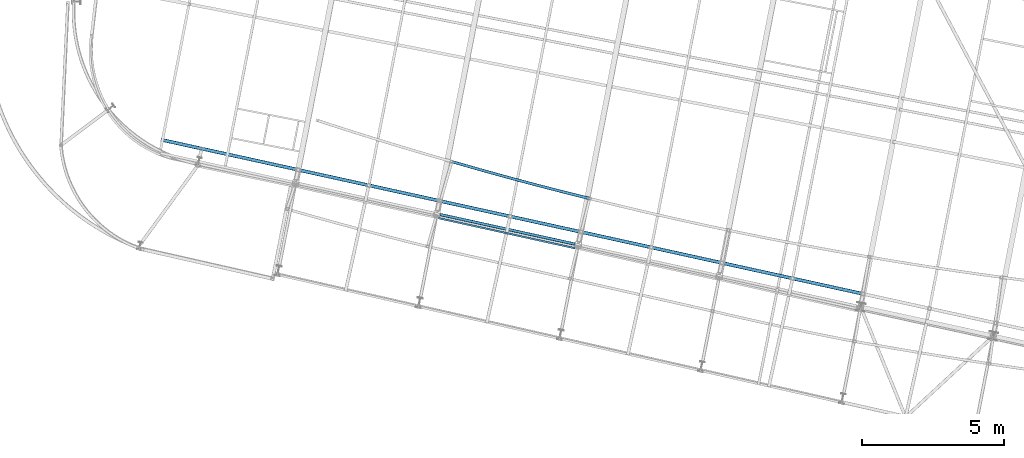
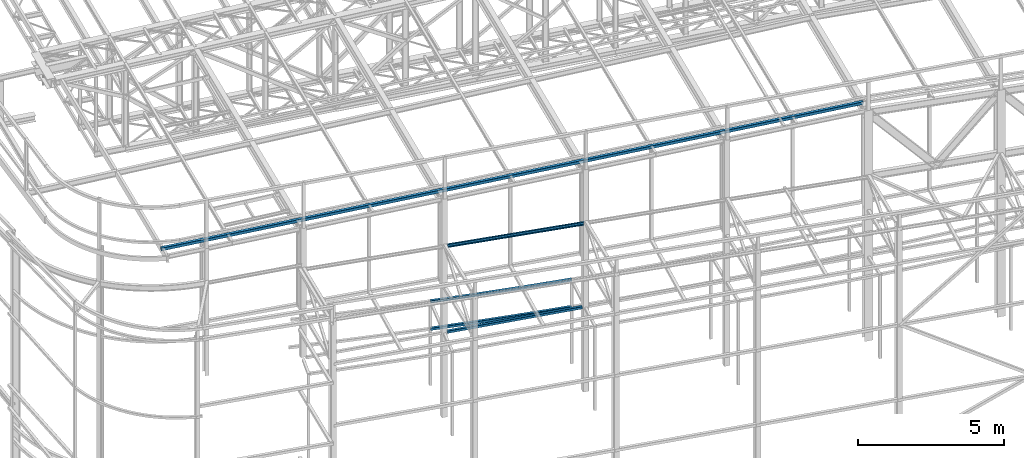
# One storey, part 34 of 215: 5 beams, 5 elements without a shape of their own.
"""IFC2X3 building model written with IfcOpenShell, lengths in millimetres."""

from ifc_helpers import new_model, entity, si_unit, frame, origin_with_axes, origin_2d_with_axis, place, context, subcontext, project, spatial, hollow_rectangle, u_section, extrude, clip, halfspace, material, type_object, element, aggregate, save


model = new_model("IFC2X3")

# Units and contexts
model_context = context("Model", 3, precision=1e-05, world=origin_with_axes())
body_context = subcontext(model_context, "Body", "Model", "MODEL_VIEW")
ifc_project = project(units=[si_unit("LENGTHUNIT", "METRE", prefix="MILLI"), si_unit("AREAUNIT", "SQUARE_METRE"), si_unit("VOLUMEUNIT", "CUBIC_METRE"), si_unit("MASSUNIT", "GRAM", prefix="KILO"), si_unit("TIMEUNIT", "SECOND"), si_unit("PLANEANGLEUNIT", "RADIAN"), si_unit("SOLIDANGLEUNIT", "STERADIAN"), si_unit("THERMODYNAMICTEMPERATUREUNIT", "DEGREE_CELSIUS"), si_unit("LUMINOUSINTENSITYUNIT", "LUMEN")], contexts=[model_context])

# Site, building, storey
site_placement = place(None, origin_with_axes())
site = spatial("IfcSite", under=ifc_project, at=site_placement, CompositionType="ELEMENT")
building_placement = place(site_placement, origin_with_axes())
building = spatial("IfcBuilding", under=site, at=building_placement, Name="Undefined", CompositionType="ELEMENT")
storey_placement = place(building_placement, origin_with_axes())
storey = spatial("IfcBuildingStorey", under=building, at=storey_placement, Name="Undefined", CompositionType="ELEMENT", Elevation=0.0)

# Assembly, beam
assembly_1_placement = place(storey_placement, origin_with_axes())
assembly_1 = element("IfcElementAssembly", 1, at=assembly_1_placement, inside=storey, Name="Steel Assembly", AssemblyPlace="NOTDEFINED", PredefinedType="RIGID_FRAME")
ifc_material = material(Name="STEEL/S275JR")
beam_type_1 = type_object("IfcBeamType", PredefinedType="NOTDEFINED")
beam_1_placement = place(assembly_1_placement, frame((50543.4160313123, 10936.7000340039, 5610.00000147687), z_axis=(0.258677071921256, 0.965963856705956, 0.0), x_axis=(0.965963856705956, -0.258677071921257, 0.0)))
beam_1 = element("IfcBeam", 2, at=beam_1_placement, type_object=beam_type_1, material=ifc_material, Name="POUTRE", context=body_context, shape_type="SweptSolid", body=[
    entity("IfcRevolvedAreaSolid", entity("IfcRectangleHollowProfileDef", "AREA", None, entity("IfcAxis2Placement2D", entity("IfcCartesianPoint", [0.0, 0.0]), entity("IfcDirection", [1.0, 0.0])), 100.0, 100.0, 4.0, 4.0, 8.0), entity("IfcAxis2Placement3D", entity("IfcCartesianPoint", [5019.69840847502, 1.81898940354586e-12, -2.78649237488161e-13]), entity("IfcDirection", [-0.999781248885502, 0.0, -0.0209154100353125]), entity("IfcDirection", [-6.93889390390723e-18, -1.0, -3.46944695195361e-18])), entity("IfcAxis1Placement", entity("IfcCartesianPoint", [0.0, 120000.0, 0.0]), entity("IfcDirection", [-1.0, 0.0, 0.0])), 0.0418338705170513),
])
aggregate(assembly_1, [beam_1])

assembly_2_placement = place(storey_placement, origin_with_axes())
assembly_2 = element("IfcElementAssembly", 3, at=assembly_2_placement, inside=storey, Name="Steel Assembly", AssemblyPlace="NOTDEFINED", PredefinedType="RIGID_FRAME")
beam_2_placement = place(assembly_2_placement, frame((50017.7644912359, 9100.61483732924, 6760.00000147687), z_axis=(0.214484663892396, 0.976727356509976, 0.0), x_axis=(0.976727356509977, -0.214484663892393, 0.0)))
beam_2 = element("IfcBeam", 4, at=beam_2_placement, type_object=beam_type_1, material=ifc_material, Name="POUTRE", context=body_context, shape_type="Clipping", body=[
    clip(clip(extrude(hollow_rectangle(XDim=100.0, YDim=100.0, WallThickness=4.0, InnerFilletRadius=4.0, OuterFilletRadius=8.0, at=origin_2d_with_axis()), frame((5018.47848766564, 0.0, 2.78581518279621e-13), z_axis=(-1.0, 0.0, 0.0), x_axis=(-6.93889390390723e-18, -1.0, -3.46944695195361e-18)), (0.0, 0.0, 1.0), 4948.6), halfspace(frame((4980.07130290705, -50.0, -77.4872571001106), z_axis=(0.999733029085594, 0.0, 0.0231056390377605), x_axis=(-6.93889390390723e-18, -1.0, -3.46944695195361e-18)), False)), halfspace(frame((111.653906554173, -50.0, -70.292034045262), z_axis=(0.999733029085594, 0.0, 0.0231056390377605), x_axis=(-6.93889390390723e-18, -1.0, -3.46944695195361e-18)), True)),
])
aggregate(assembly_2, [beam_2])

assembly_3_placement = place(storey_placement, origin_with_axes())
assembly_3 = element("IfcElementAssembly", 5, at=assembly_3_placement, inside=storey, Name="Steel Assembly", AssemblyPlace="NOTDEFINED", PredefinedType="RIGID_FRAME")
beam_3_placement = place(assembly_3_placement, frame((50543.4160313176, 10936.7000339951, 6760.00000147687), z_axis=(0.258677071921256, 0.965963856705956, 0.0), x_axis=(0.965963856705956, -0.258677071921257, 0.0)))
beam_3 = element("IfcBeam", 6, at=beam_3_placement, type_object=beam_type_1, material=ifc_material, Name="POUTRE", context=body_context, shape_type="SweptSolid", body=[
    entity("IfcRevolvedAreaSolid", entity("IfcRectangleHollowProfileDef", "AREA", None, entity("IfcAxis2Placement2D", entity("IfcCartesianPoint", [0.0, 0.0]), entity("IfcDirection", [1.0, 0.0])), 100.0, 100.0, 4.0, 4.0, 8.0), entity("IfcAxis2Placement3D", entity("IfcCartesianPoint", [5019.69840847502, 1.81898940354586e-12, -2.78649237488161e-13]), entity("IfcDirection", [-0.999781248885502, 0.0, -0.0209154100353125]), entity("IfcDirection", [-6.93889390390723e-18, -1.0, -3.46944695195361e-18])), entity("IfcAxis1Placement", entity("IfcCartesianPoint", [0.0, 120000.0, 0.0]), entity("IfcDirection", [-1.0, 0.0, 0.0])), 0.0418338705165097),
])
aggregate(assembly_3, [beam_3])

assembly_4_placement = place(storey_placement, origin_with_axes())
assembly_4 = element("IfcElementAssembly", 7, at=assembly_4_placement, inside=storey, Name="Steel Assembly", AssemblyPlace="NOTDEFINED", PredefinedType="RIGID_FRAME")
beam_type_2 = type_object("IfcBeamType", PredefinedType="NOTDEFINED")
beam_4_placement = place(assembly_4_placement, frame((65009.5686032957, 6282.83921804559, 12860.0288836317), z_axis=(0.0302595169963337, -0.00664661199919454, -0.999519976878942), x_axis=(-0.97624656431856, 0.214436074069973, -0.0309808940101094)))
beam_4 = element("IfcBeam", 8, at=beam_4_placement, type_object=beam_type_2, material=ifc_material, Name="LISSE", context=body_context, shape_type="SweptSolid", body=[
    extrude(hollow_rectangle(XDim=120.0, YDim=120.0, WallThickness=5.0, InnerFilletRadius=5.0, OuterFilletRadius=10.0, at=origin_2d_with_axis()), frame((25300.3907865618, 2.80081538977846e-12, 0.0), z_axis=(-1.0, 0.0, 0.0), x_axis=(-6.93889390390723e-18, -1.0, -3.46944695195361e-18)), (0.0, 0.0, 1.0), 25300.4),
])
aggregate(assembly_4, [beam_4])

assembly_5_placement = place(storey_placement, origin_with_axes())
assembly_5 = element("IfcElementAssembly", 9, at=assembly_5_placement, inside=storey, Name="Steel Assembly", AssemblyPlace="NOTDEFINED", PredefinedType="RIGID_FRAME")
beam_type_3 = type_object("IfcBeamType", Name="UPN140", PredefinedType="NOTDEFINED")
beam_5_placement = place(assembly_5_placement, frame((54870.248055673, 7889.08598754639, 10362.1454711309), z_axis=(-0.0195412680016938, 0.00431098300037378, -0.999799757086616), x_axis=(-0.976323929761909, 0.215386021947475, 0.0200111399951202)))
beam_5 = element("IfcBeam", 10, at=beam_5_placement, type_object=beam_type_3, material=ifc_material, ObjectType="UPN140", context=body_context, shape_type="SweptSolid", body=[
    extrude(u_section(Depth=140.0, FlangeWidth=60.0, WebThickness=7.0, FlangeThickness=10.0, FilletRadius=10.0, EdgeRadius=5.0, FlangeSlope=0.0798299857122373, at=origin_2d_with_axis()), frame((4905.82968287624, -3.570017360686e-12, 3.40410316801172e-14), z_axis=(-1.0, 0.0, 0.0), x_axis=(-6.93889390390723e-18, -1.0, -3.46944695195361e-18)), (0.0, 0.0, 1.0), 4905.8),
])
aggregate(assembly_5, [beam_5])

save(model, "model.ifc")
